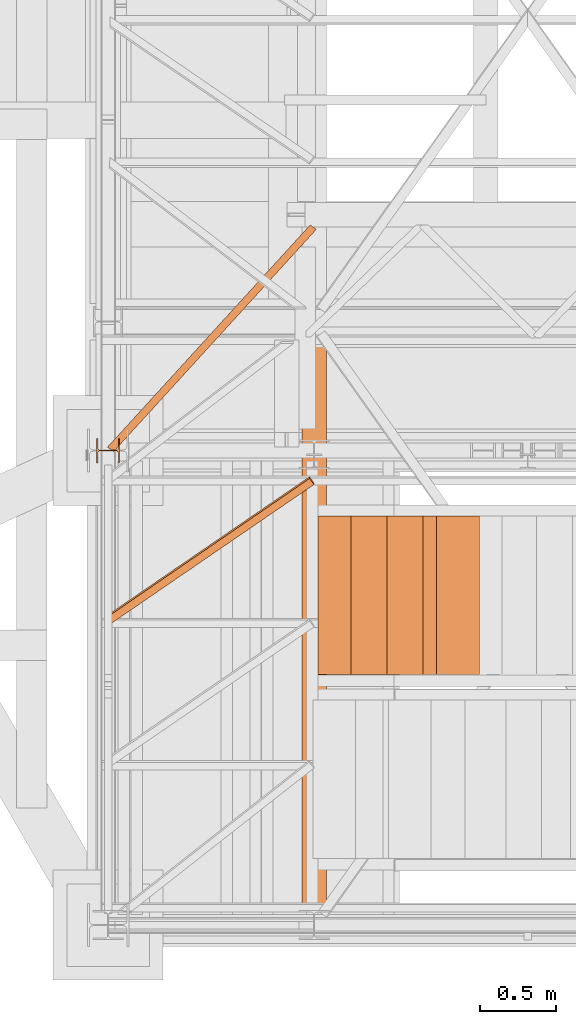
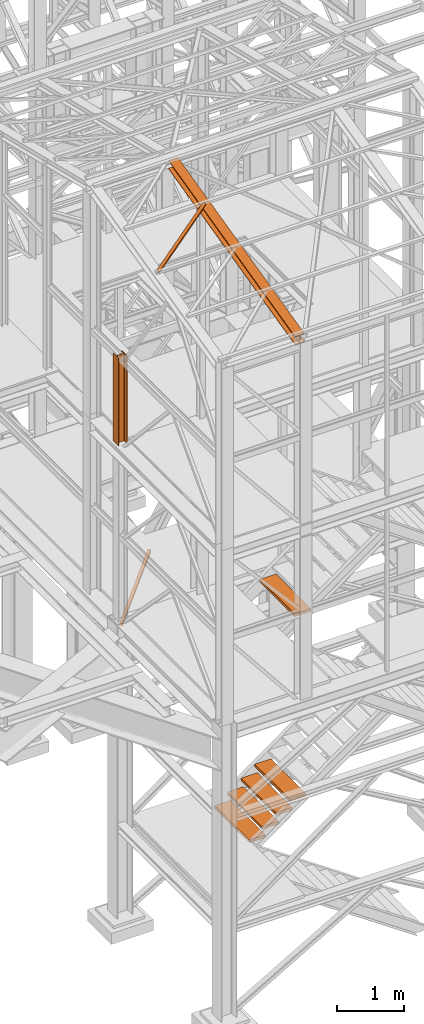
# One storey, part 14 of 208: 9 proxies.
"""IFC2X3 building model written with IfcOpenShell, lengths in millimetres."""

from ifc_helpers import new_model, entity, si_unit, converted_unit, frame, origin, origin_with_axes, place, context, subcontext, project, spatial, faceted_brep, element, save


model = new_model("IFC2X3")

# Units and contexts
model_context = context("Model", 3, precision=1e-05, world=origin())
plan_context = context("Plan", 3, precision=1e-05, world=origin())
body_context = subcontext(model_context, "Body", "Model", "MODEL_VIEW")
ifc_project = project(units=[si_unit("LENGTHUNIT", "METRE", prefix="MILLI"), converted_unit("PLANEANGLEUNIT", "DEGREE", entity("IfcPlaneAngleMeasure", 0.0174532925199433), si_unit("PLANEANGLEUNIT", "RADIAN"), dimensions=[0, 0, 0, 0, 0, 0, 0]), si_unit("AREAUNIT", "SQUARE_METRE"), si_unit("VOLUMEUNIT", "CUBIC_METRE")], contexts=[model_context, plan_context])

# Building, storey
building_placement = place(None, origin())
building = spatial("IfcBuilding", under=ifc_project, at=building_placement, CompositionType="COMPLEX")
storey_placement = place(building_placement, origin_with_axes())
storey = spatial("IfcBuildingStorey", under=building, at=storey_placement, Name="Geschoss", CompositionType="ELEMENT")

# Proxies
proxy_1_placement = place(storey_placement, frame((1193.91481775296, -22069.74199833824, 5124.989999999998), z_axis=(0.0, 0.0, 1.0), x_axis=(1.0, 0.0, 0.0)))
element("IfcBuildingElementProxy", 1, at=proxy_1_placement, inside=storey, context=body_context, shape_type="Brep", body=[
    faceted_brep([(1328.644641054631, 1486.462747256283, 50.01000000000022), (0.009999999999990905, 29.86187876008262, 50.01000000000022), (0.009999999999990905, 29.86187876008262, 0.01000000000021828), (1328.644641054631, 1486.462747256283, 0.01000000000021828), (1328.644641054631, 1486.462747256283, 0.01000000000021828), (0.009999999999990905, 29.86187876008262, 0.01000000000021828), (40.12066360076256, 0.01000000000203727, 0.01000000000021828), (1368.755304655396, 1456.610868496202, 0.01000000000021828), (1368.755304655396, 1456.610868496202, 0.01000000000021828), (40.12066360076256, 0.01000000000203727, 0.01000000000021828), (40.12066360076256, 0.01000000000203727, 50.01000000000022), (1368.755304655396, 1456.610868496202, 50.01000000000022), (1368.755304655396, 1456.610868496202, 50.01000000000022), (40.12066360076256, 0.01000000000203727, 50.01000000000022), (0.009999999999990905, 29.86187876008262, 50.01000000000022), (1328.644641054631, 1486.462747256283, 50.01000000000022), (1328.644641054631, 1486.462747256283, 50.01000000000022), (1328.644641054631, 1486.462747256283, 0.01000000000021828), (1368.755304655396, 1456.610868496202, 0.01000000000021828), (1368.755304655396, 1456.610868496202, 50.01000000000022), (1331.853494142692, 1484.074596955477, 4.010000000000218), (1331.853494142692, 1484.074596955477, 46.01000000000022), (1365.546451567335, 1458.999018797011, 46.01000000000022), (1365.546451567335, 1458.999018797011, 4.010000000000218), (0.009999999999990905, 29.86187876008262, 50.01000000000022), (40.12066360076256, 0.01000000000203727, 50.01000000000022), (40.12066360076256, 0.01000000000203727, 0.01000000000021828), (0.009999999999990905, 29.86187876008262, 0.01000000000021828), (36.91181051270155, 2.398150300810812, 46.01000000000022), (3.218853088060996, 27.47372845927748, 46.01000000000022), (3.218853088060996, 27.47372845927748, 4.010000000000218), (36.91181051270155, 2.398150300810812, 4.010000000000218), (1331.853494142692, 1484.074596955477, 46.01000000000022), (1331.853494142692, 1484.074596955477, 4.010000000000218), (3.218853088060996, 27.47372845927748, 4.010000000000218), (3.218853088060996, 27.47372845927748, 46.01000000000022), (1331.853494142692, 1484.074596955477, 4.010000000000218), (1365.546451567335, 1458.999018797011, 4.010000000000218), (36.91181051270155, 2.398150300810812, 4.010000000000218), (3.218853088060996, 27.47372845927748, 4.010000000000218), (1365.546451567335, 1458.999018797011, 4.010000000000218), (1365.546451567335, 1458.999018797011, 46.01000000000022), (36.91181051270155, 2.398150300810812, 46.01000000000022), (36.91181051270155, 2.398150300810812, 4.010000000000218), (1365.546451567335, 1458.999018797011, 46.01000000000022), (1331.853494142692, 1484.074596955477, 46.01000000000022), (3.218853088060996, 27.47372845927748, 46.01000000000022), (36.91181051270155, 2.398150300810812, 46.01000000000022)], [[[0, 1, 2, 3]], [[4, 5, 6, 7]], [[8, 9, 10, 11]], [[12, 13, 14, 15]], [[16, 17, 18, 19], [20, 21, 22, 23]], [[24, 25, 26, 27], [28, 29, 30, 31]], [[32, 33, 34, 35]], [[36, 37, 38, 39]], [[40, 41, 42, 43]], [[44, 45, 46, 47]]], orient=[[False], [False], [False], [False], [False, False], [False, False], [False], [False], [False], [False]]),
])
proxy_2_placement = place(storey_placement, frame((3263.130870336297, -23530.42800187884, 2109.990001055714), z_axis=(0.0, 0.0, 1.0), x_axis=(1.0, 0.0, 0.0)))
element("IfcBuildingElementProxy", 2, at=proxy_2_placement, inside=storey, context=body_context, shape_type="Brep", body=[
    faceted_brep([(0.01000000000021828, 0.00999999999839929, 0.01000000000021828), (280.2746556316183, 0.00999999999839929, 0.01000000000021828), (280.2746556316183, 1037.717170711916, 0.01000000000021828), (0.01000000000021828, 1037.717170711916, 0.01000000000021828), (280.2746556316183, 0.00999999999839929, 50.01000000000022), (0.01000000000021828, 0.00999999999839929, 50.01000000000022), (0.01000000000021828, 1037.717170711916, 50.01000000000022), (280.2746556316183, 1037.717170711916, 50.01000000000022), (280.2746556316183, 0.00999999999839929, 0.01000000000021828), (0.01000000000021828, 0.00999999999839929, 0.01000000000021828), (0.01000000000021828, 0.00999999999839929, 50.01000000000022), (280.2746556316183, 0.00999999999839929, 50.01000000000022), (280.2746556316183, 1037.717170711916, 0.01000000000021828), (280.2746556316183, 0.00999999999839929, 0.01000000000021828), (280.2746556316183, 0.00999999999839929, 50.01000000000022), (280.2746556316183, 1037.717170711916, 50.01000000000022), (0.01000000000021828, 1037.717170711916, 0.01000000000021828), (280.2746556316183, 1037.717170711916, 0.01000000000021828), (280.2746556316183, 1037.717170711916, 50.01000000000022), (0.01000000000021828, 1037.717170711916, 50.01000000000022), (0.01000000000021828, 0.00999999999839929, 0.01000000000021828), (0.01000000000021828, 1037.717170711916, 0.01000000000021828), (0.01000000000021828, 1037.717170711916, 50.01000000000022), (0.01000000000021828, 0.00999999999839929, 50.01000000000022)], [[[0, 1, 2, 3]], [[4, 5, 6, 7]], [[8, 9, 10, 11]], [[12, 13, 14, 15]], [[16, 17, 18, 19]], [[20, 21, 22, 23]]], orient=[[False], [False], [False], [False], [False], [False]]),
])
for number, where, z_axis, x_axis in (
    (3, (2573.108528797217, -23530.42800187884, 1599.990001055713), (0.0, 0.0, 1.0), (1.0, 0.0, 0.0)),
    (4, (2791.281494502201, -23530.42800187884, 1769.990001055714), (0.0, 0.0, 1.0), (1.0, 0.0, 0.0)),
    (5, (3027.206182419249, -23530.42800187884, 1939.990001055714), (0.0, 0.0, 1.0), (1.0, 0.0, 0.0)),
):
    element("IfcBuildingElementProxy", number, at=place(storey_placement, frame(where, z_axis=z_axis, x_axis=x_axis)), inside=storey, context=body_context, shape_type="Brep", body=[
        faceted_brep([(0.01000000000021828, 0.00999999999839929, 0.009999999999990905), (280.2746556316183, 0.00999999999839929, 0.009999999999990905), (280.2746556316183, 1037.717170711916, 0.009999999999990905), (0.01000000000021828, 1037.717170711916, 0.009999999999990905), (280.2746556316183, 0.00999999999839929, 50.00999999999999), (0.01000000000021828, 0.00999999999839929, 50.00999999999999), (0.01000000000021828, 1037.717170711916, 50.00999999999999), (280.2746556316183, 1037.717170711916, 50.00999999999999), (280.2746556316183, 0.00999999999839929, 0.009999999999990905), (0.01000000000021828, 0.00999999999839929, 0.009999999999990905), (0.01000000000021828, 0.00999999999839929, 50.00999999999999), (280.2746556316183, 0.00999999999839929, 50.00999999999999), (280.2746556316183, 1037.717170711916, 0.009999999999990905), (280.2746556316183, 0.00999999999839929, 0.009999999999990905), (280.2746556316183, 0.00999999999839929, 50.00999999999999), (280.2746556316183, 1037.717170711916, 50.00999999999999), (0.01000000000021828, 1037.717170711916, 0.009999999999990905), (280.2746556316183, 1037.717170711916, 0.009999999999990905), (280.2746556316183, 1037.717170711916, 50.00999999999999), (0.01000000000021828, 1037.717170711916, 50.00999999999999), (0.01000000000021828, 0.00999999999839929, 0.009999999999990905), (0.01000000000021828, 1037.717170711916, 0.009999999999990905), (0.01000000000021828, 1037.717170711916, 50.00999999999999), (0.01000000000021828, 0.00999999999839929, 50.00999999999999)], [[[0, 1, 2, 3]], [[4, 5, 6, 7]], [[8, 9, 10, 11]], [[12, 13, 14, 15]], [[16, 17, 18, 19]], [[20, 21, 22, 23]]], orient=[[False], [False], [False], [False], [False], [False]]),
    ])
proxy_3_placement = place(storey_placement, frame((3350.427385940221, -23530.42800187884, 5443.518109803212), z_axis=(0.0, 0.0, 1.0), x_axis=(1.0, 0.0, 0.0)))
element("IfcBuildingElementProxy", 6, at=proxy_3_placement, inside=storey, context=body_context, shape_type="Brep", body=[
    faceted_brep([(0.01000000000021828, 0.00999999999839929, 0.01000000000021828), (280.2746556316183, 0.00999999999839929, 0.01000000000021828), (280.2746556316183, 1037.717170711916, 0.01000000000021828), (0.01000000000021828, 1037.717170711916, 0.01000000000021828), (280.2746556316183, 0.00999999999839929, 50.01000000000022), (0.01000000000021828, 0.00999999999839929, 50.01000000000022), (0.01000000000021828, 1037.717170711916, 50.01000000000022), (280.2746556316183, 1037.717170711916, 50.01000000000022), (280.2746556316183, 0.00999999999839929, 0.01000000000021828), (0.01000000000021828, 0.00999999999839929, 0.01000000000021828), (0.01000000000021828, 0.00999999999839929, 50.01000000000022), (280.2746556316183, 0.00999999999839929, 50.01000000000022), (280.2746556316183, 1037.717170711916, 0.01000000000021828), (280.2746556316183, 0.00999999999839929, 0.01000000000021828), (280.2746556316183, 0.00999999999839929, 50.01000000000022), (280.2746556316183, 1037.717170711916, 50.01000000000022), (0.01000000000021828, 1037.717170711916, 0.01000000000021828), (280.2746556316183, 1037.717170711916, 0.01000000000021828), (280.2746556316183, 1037.717170711916, 50.01000000000022), (0.01000000000021828, 1037.717170711916, 50.01000000000022), (0.01000000000021828, 0.00999999999839929, 0.01000000000021828), (0.01000000000021828, 1037.717170711916, 0.01000000000021828), (0.01000000000021828, 1037.717170711916, 50.01000000000022), (0.01000000000021828, 0.00999999999839929, 50.01000000000022)], [[[0, 1, 2, 3]], [[4, 5, 6, 7]], [[8, 9, 10, 11]], [[12, 13, 14, 15]], [[16, 17, 18, 19]], [[20, 21, 22, 23]]], orient=[[False], [False], [False], [False], [False], [False]]),
])
proxy_4_placement = place(storey_placement, frame((1209.754965757053, -23201.62230478293, 12214.24717333412), z_axis=(0.0, 0.0, 1.0), x_axis=(1.0, 0.0, 0.0)))
element("IfcBuildingElementProxy", 7, at=proxy_4_placement, inside=storey, context=body_context, shape_type="Brep", body=[
    faceted_brep([(1308.5389233782, 967.7692788621098, 232.0521250666225), (1337.349720073477, 928.0575343349883, 222.4128647010039), (1337.349720073477, 916.2634686381534, 271.0019582749592), (1308.5389233782, 955.9752131652713, 280.6412186405796), (0.009999999999990905, 71.25499243027662, 14.44056628674844), (1308.5389233782, 967.7692788621098, 232.0521250666225), (1308.5389233782, 955.9752131652713, 280.6412186405796), (0.009999999999990905, 59.46092673344174, 63.02965986070558), (0.009999999999990905, 11.80406569684055, 0.01000000000021828), (1337.349720073477, 928.0575343349883, 222.4128647010039), (1308.5389233782, 967.7692788621098, 232.0521250666225), (0.009999999999990905, 71.25499243027662, 14.44056628674844), (0.009999999999990905, 0.01000000000203727, 48.59909357395554), (1337.349720073477, 916.2634686381534, 271.0019582749592), (1337.349720073477, 928.0575343349883, 222.4128647010039), (0.009999999999990905, 11.80406569684055, 0.01000000000021828), (0.009999999999990905, 59.46092673344174, 63.02965986070558), (1308.5389233782, 955.9752131652713, 280.6412186405796), (1337.349720073477, 916.2634686381534, 271.0019582749592), (0.009999999999990905, 0.01000000000203727, 48.59909357395554), (0.009999999999990905, 71.25499243027662, 14.44056628674844), (0.009999999999990905, 59.46092673344174, 63.02965986070558), (0.009999999999990905, 0.01000000000203727, 48.59909357395554), (0.009999999999990905, 11.80406569684055, 0.01000000000021828)], [[[0, 1, 2, 3]], [[4, 5, 6, 7]], [[8, 9, 10, 11]], [[12, 13, 14, 15]], [[16, 17, 18, 19]], [[20, 21, 22, 23]]], orient=[[False], [False], [False], [False], [False], [False]]),
])
proxy_5_placement = place(storey_placement, frame((2468.254966591505, -25077.57437538435, 11628.70515179705), z_axis=(0.0, 0.0, 1.0), x_axis=(1.0, 0.0, 0.0)))
element("IfcBuildingElementProxy", 8, at=proxy_5_placement, inside=storey, context=body_context, shape_type="Brep", body=[
    faceted_brep([(160.01001132489, 3780.009979404025, 1074.775244917653), (160.01001132488, 0.00999999999839929, 156.4315054631916), (0.01000000000021828, 0.00999999999839929, 156.4315054631916), (0.01000000000703949, 3780.009979404025, 1074.775244917653), (0.01000000000703949, 3780.009979404025, 1074.775244917653), (0.01000000000021828, 0.00999999999839929, 156.4315054631916), (0.01000000000021828, 0.00999999999839929, 147.1697029728093), (0.01000000000703949, 3780.009979404025, 1065.513442427271), (0.01000000000703949, 3780.009979404025, 1065.513442427271), (0.01000000000021828, 0.00999999999839929, 147.1697029728093), (62.01000457465671, 0.00999999999839929, 147.1697029728093), (62.01000457466307, 3780.009979404025, 1065.513442427271), (62.01000457466307, 3780.009979404025, 1065.513442427271), (62.01000457465671, 0.00999999999839929, 147.1697029728093), (69.77318079977886, 0.00999999999839929, 145.5707163655079), (69.77318079978886, 3780.009979404025, 1063.914455819968), (69.77318079978886, 3780.009979404025, 1063.914455819968), (69.77318079977886, 0.00999999999839929, 145.5707163655079), (75.45621545821086, 0.00999999999839929, 139.7223691397903), (75.45621545822132, 3780.009979404025, 1058.066108594254), (75.45621545822132, 3780.009979404025, 1058.066108594254), (75.45621545821086, 0.00999999999839929, 139.7223691397903), (77.0100056363608, 0.00999999999839929, 131.7333744340358), (77.0100056363708, 3780.009979404025, 1050.077113888498), (77.0100056363708, 3780.009979404025, 1050.077113888498), (77.0100056363608, 0.00999999999839929, 131.7333744340358), (77.0100056363608, 0.00999999999839929, 24.70813486281259), (77.0100056363708, 3780.009979404025, 943.0518743172743), (77.0100056363708, 3780.009979404025, 943.0518743172743), (77.0100056363608, 0.00999999999839929, 24.70813486281259), (75.45621545821086, 0.00999999999839929, 16.71913632339965), (75.45621545822087, 3780.009979404025, 935.0628757778613), (75.45621545822087, 3780.009979404025, 935.0628757778613), (75.45621545821086, 0.00999999999839929, 16.71913632339965), (69.77318079977886, 0.00999999999839929, 10.87078909768752), (69.77318079978886, 3780.009979404025, 929.2145285521474), (69.77318079978886, 3780.009979404025, 929.2145285521474), (69.77318079977886, 0.00999999999839929, 10.87078909768752), (62.01000457465307, 0.00999999999839929, 9.27180249038247), (62.01000457466307, 3780.009979404025, 927.6155419448442), (62.01000457466307, 3780.009979404025, 927.6155419448442), (62.01000457465307, 0.00999999999839929, 9.27180249038247), (0.01000000000021828, 0.00999999999839929, 9.27180249038247), (0.01000000000703949, 3780.009979404025, 927.6155419448423), (0.01000000000703949, 3780.009979404025, 927.6155419448423), (0.01000000000021828, 0.00999999999839929, 9.27180249038247), (0.01000000000021828, 0.00999999999839929, 0.01000000000021828), (0.01000000000658474, 3780.009979404025, 918.3537394544601), (0.01000000000658474, 3780.009979404025, 918.3537394544601), (0.01000000000021828, 0.00999999999839929, 0.01000000000021828), (160.0100113248827, 0.00999999999839929, 0.01000000000021828), (160.01001132489, 3780.009979404025, 918.3537394544619), (160.01001132489, 3780.009979404025, 918.3537394544619), (160.0100113248827, 0.00999999999839929, 0.01000000000021828), (160.0100113248836, 0.00999999999839929, 9.27180249038065), (160.01001132489, 3780.009979404025, 927.6155419448423), (160.01001132489, 3780.009979404025, 927.6155419448423), (160.0100113248836, 0.00999999999839929, 9.27180249038065), (98.0100067502226, 0.00999999999839929, 9.27180249038247), (98.0100067502326, 3780.009979404025, 927.6155419448423), (98.0100067502326, 3780.009979404025, 927.6155419448423), (98.0100067502226, 0.00999999999839929, 9.27180249038247), (90.24683052509681, 0.00999999999839929, 10.87078909768752), (90.24683052510682, 3780.009979404025, 929.2145285521474), (90.24683052510682, 3780.009979404025, 929.2145285521474), (90.24683052509681, 0.00999999999839929, 10.87078909768752), (84.5637958666648, 0.00999999999839929, 16.71913632339783), (84.56379586667481, 3780.009979404025, 935.0628757778613), (84.56379586667481, 3780.009979404025, 935.0628757778613), (84.5637958666648, 0.00999999999839929, 16.71913632339783), (83.01000568851487, 0.00999999999839929, 24.70813486281077), (83.01000568852487, 3780.009979404025, 943.0518743172743), (83.01000568852487, 3780.009979404025, 943.0518743172743), (83.01000568851487, 0.00999999999839929, 24.70813486281077), (83.01000568851532, 0.00999999999839929, 131.733374434034), (83.01000568852487, 3780.009979404025, 1050.077113888496), (83.01000568852487, 3780.009979404025, 1050.077113888496), (83.01000568851532, 0.00999999999839929, 131.733374434034), (84.5637958666648, 0.00999999999839929, 139.7223691397903), (84.56379586667526, 3780.009979404025, 1058.066108594254), (84.56379586667526, 3780.009979404025, 1058.066108594254), (84.5637958666648, 0.00999999999839929, 139.7223691397903), (90.24683052509727, 0.00999999999839929, 145.5707163655079), (90.24683052510727, 3780.009979404025, 1063.914455819968), (90.24683052510727, 3780.009979404025, 1063.914455819968), (90.24683052509727, 0.00999999999839929, 145.5707163655079), (98.0100067502226, 0.00999999999839929, 147.1697029728093), (98.0100067502326, 3780.009979404025, 1065.513442427271), (98.0100067502326, 3780.009979404025, 1065.513442427271), (98.0100067502226, 0.00999999999839929, 147.1697029728093), (160.0100113248832, 0.00999999999839929, 147.1697029728093), (160.01001132489, 3780.009979404025, 1065.513442427271), (160.01001132489, 3780.009979404025, 1065.513442427271), (160.0100113248832, 0.00999999999839929, 147.1697029728093), (160.01001132488, 0.00999999999839929, 156.4315054631916), (160.01001132489, 3780.009979404025, 1074.775244917653), (0.01000000000703949, 3780.009979404025, 1074.775244917653), (0.01000000000703949, 3780.009979404025, 1065.513442427271), (62.01000457466307, 3780.009979404025, 1065.513442427271), (69.77318079978886, 3780.009979404025, 1063.914455819968), (75.45621545822132, 3780.009979404025, 1058.066108594254), (77.0100056363708, 3780.009979404025, 1050.077113888498), (77.0100056363708, 3780.009979404025, 943.0518743172743), (75.45621545822087, 3780.009979404025, 935.0628757778613), (69.77318079978886, 3780.009979404025, 929.2145285521474), (62.01000457466307, 3780.009979404025, 927.6155419448442), (0.01000000000703949, 3780.009979404025, 927.6155419448423), (0.01000000000658474, 3780.009979404025, 918.3537394544601), (160.01001132489, 3780.009979404025, 918.3537394544619), (160.01001132489, 3780.009979404025, 927.6155419448423), (98.0100067502326, 3780.009979404025, 927.6155419448423), (90.24683052510682, 3780.009979404025, 929.2145285521474), (84.56379586667481, 3780.009979404025, 935.0628757778613), (83.01000568852487, 3780.009979404025, 943.0518743172743), (83.01000568852487, 3780.009979404025, 1050.077113888496), (84.56379586667526, 3780.009979404025, 1058.066108594254), (90.24683052510727, 3780.009979404025, 1063.914455819968), (98.0100067502326, 3780.009979404025, 1065.513442427271), (160.01001132489, 3780.009979404025, 1065.513442427271), (160.01001132489, 3780.009979404025, 1074.775244917653), (160.01001132488, 0.00999999999839929, 156.4315054631916), (160.0100113248832, 0.00999999999839929, 147.1697029728093), (98.0100067502226, 0.00999999999839929, 147.1697029728093), (90.24683052509727, 0.00999999999839929, 145.5707163655079), (84.5637958666648, 0.00999999999839929, 139.7223691397903), (83.01000568851532, 0.00999999999839929, 131.733374434034), (83.01000568851487, 0.00999999999839929, 24.70813486281077), (84.5637958666648, 0.00999999999839929, 16.71913632339783), (90.24683052509681, 0.00999999999839929, 10.87078909768752), (98.0100067502226, 0.00999999999839929, 9.27180249038247), (160.0100113248836, 0.00999999999839929, 9.27180249038065), (160.0100113248827, 0.00999999999839929, 0.01000000000021828), (0.01000000000021828, 0.00999999999839929, 0.01000000000021828), (0.01000000000021828, 0.00999999999839929, 9.27180249038247), (62.01000457465307, 0.00999999999839929, 9.27180249038247), (69.77318079977886, 0.00999999999839929, 10.87078909768752), (75.45621545821086, 0.00999999999839929, 16.71913632339965), (77.0100056363608, 0.00999999999839929, 24.70813486281259), (77.0100056363608, 0.00999999999839929, 131.7333744340358), (75.45621545821086, 0.00999999999839929, 139.7223691397903), (69.77318079977886, 0.00999999999839929, 145.5707163655079), (62.01000457465671, 0.00999999999839929, 147.1697029728093), (0.01000000000021828, 0.00999999999839929, 147.1697029728093), (0.01000000000021828, 0.00999999999839929, 156.4315054631916)], [[[0, 1, 2, 3]], [[4, 5, 6, 7]], [[8, 9, 10, 11]], [[12, 13, 14, 15]], [[16, 17, 18, 19]], [[20, 21, 22, 23]], [[24, 25, 26, 27]], [[28, 29, 30, 31]], [[32, 33, 34, 35]], [[36, 37, 38, 39]], [[40, 41, 42, 43]], [[44, 45, 46, 47]], [[48, 49, 50, 51]], [[52, 53, 54, 55]], [[56, 57, 58, 59]], [[60, 61, 62, 63]], [[64, 65, 66, 67]], [[68, 69, 70, 71]], [[72, 73, 74, 75]], [[76, 77, 78, 79]], [[80, 81, 82, 83]], [[84, 85, 86, 87]], [[88, 89, 90, 91]], [[92, 93, 94, 95]], [[96, 97, 98, 99, 100, 101, 102, 103, 104, 105, 106, 107, 108, 109, 110, 111, 112, 113, 114, 115, 116, 117, 118, 119]], [[120, 121, 122, 123, 124, 125, 126, 127, 128, 129, 130, 131, 132, 133, 134, 135, 136, 137, 138, 139, 140, 141, 142, 143]]], orient=[[False], [False], [False], [False], [False], [False], [False], [False], [False], [False], [False], [False], [False], [False], [False], [False], [False], [False], [False], [False], [False], [False], [False], [False], [False], [False]]),
])
proxy_6_placement = place(storey_placement, frame((1122.164811912571, -22142.57439598033, 8484.990002086159), z_axis=(0.0, 0.0, 1.0), x_axis=(1.0, 0.0, 0.0)))
element("IfcBuildingElementProxy", 9, at=proxy_6_placement, inside=storey, context=body_context, shape_type="Brep", body=[
    faceted_brep([(152.0100100135803, 0.01000000000203727, 0.00999999999839929), (152.0100100135803, 160.0100113248845, 0.00999999999839929), (143.0100066757202, 160.0100113248845, 0.00999999999839929), (143.0100066757202, 98.01000675022806, 0.00999999999839929), (141.4562178945541, 90.24683052510227, 0.00999999999839929), (135.7731832361221, 84.56379586667026, 0.00999999999839929), (128.0100098049641, 83.01000568852032, 0.00999999999839929), (24.01000393390655, 83.01000568852032, 0.00999999999839929), (16.24682677745818, 84.56379586667026, 0.00999999999839929), (10.56379211902618, 90.24683052510227, 0.00999999999839929), (9.010003337860098, 98.01000675022806, 0.00999999999839929), (9.010003337860098, 160.0100113248845, 0.00999999999839929), (0.009999999999990905, 160.0100113248845, 0.00999999999839929), (0.009999999999990905, 0.01000000000203727, 0.00999999999839929), (9.010003337860098, 0.01000000000203727, 0.00999999999839929), (9.010003337860098, 62.01000457465852, 0.00999999999839929), (10.56379211902618, 69.77318079978431, 0.00999999999839929), (16.24682677745818, 75.45621545821632, 0.00999999999839929), (24.01000393390655, 77.01000563636626, 0.00999999999839929), (128.0100098049641, 77.01000563636626, 0.00999999999839929), (135.7731832361221, 75.45621545821632, 0.00999999999839929), (141.4562178945541, 69.77318079978431, 0.00999999999839929), (143.0100066757202, 62.01000457465852, 0.00999999999839929), (143.0100066757202, 0.01000000000203727, 0.00999999999839929), (152.0100100135803, 160.0100113248845, 0.00999999999839929), (152.0100100135803, 0.01000000000203727, 0.00999999999839929), (152.0100100135803, 0.01000000000203727, 1595.009998658896), (152.0100100135812, 160.0100113248882, 1595.009998658894), (143.0100066757202, 160.0100113248845, 0.00999999999839929), (152.0100100135803, 160.0100113248845, 0.00999999999839929), (152.0100100135812, 160.0100113248882, 1595.009998658894), (143.0100066757202, 160.0100113248845, 1595.009998658894), (143.0100066757202, 98.01000675022806, 0.00999999999839929), (143.0100066757202, 160.0100113248845, 0.00999999999839929), (143.0100066757202, 160.0100113248845, 1595.009998658894), (143.0100066757202, 98.01000675022806, 1595.009998658894), (141.4562178945541, 90.24683052510227, 0.00999999999839929), (143.0100066757202, 98.01000675022806, 0.00999999999839929), (143.0100066757202, 98.01000675022806, 1595.009998658894), (141.4562178945541, 90.24683052510227, 1595.009998658894), (135.7731832361221, 84.56379586667026, 0.00999999999839929), (141.4562178945541, 90.24683052510227, 0.00999999999839929), (141.4562178945541, 90.24683052510227, 1595.009998658894), (135.7731832361221, 84.56379586667026, 1595.009998658892), (128.0100098049641, 83.01000568852032, 0.00999999999839929), (135.7731832361221, 84.56379586667026, 0.00999999999839929), (135.7731832361221, 84.56379586667026, 1595.009998658892), (128.0100098049641, 83.01000568852032, 1595.009998658894), (24.01000393390655, 83.01000568852032, 0.00999999999839929), (128.0100098049641, 83.01000568852032, 0.00999999999839929), (128.0100098049641, 83.01000568852032, 1595.009998658894), (24.01000393390655, 83.01000568852032, 1595.009998658894), (16.24682677745818, 84.56379586667026, 0.00999999999839929), (24.01000393390655, 83.01000568852032, 0.00999999999839929), (24.01000393390655, 83.01000568852032, 1595.009998658894), (16.24682677745818, 84.56379586667026, 1595.009998658894), (10.56379211902618, 90.24683052510227, 0.00999999999839929), (16.24682677745818, 84.56379586667026, 0.00999999999839929), (16.24682677745818, 84.56379586667026, 1595.009998658894), (10.56379211902618, 90.24683052510227, 1595.009998658894), (9.010003337860098, 98.01000675022806, 0.00999999999839929), (10.56379211902618, 90.24683052510227, 0.00999999999839929), (10.56379211902618, 90.24683052510227, 1595.009998658894), (9.010003337860098, 98.01000675022806, 1595.009998658894), (9.010003337860098, 160.0100113248845, 0.00999999999839929), (9.010003337860098, 98.01000675022806, 0.00999999999839929), (9.010003337860098, 98.01000675022806, 1595.009998658894), (9.010003337860098, 160.0100113248882, 1595.009998658894), (0.009999999999990905, 160.0100113248845, 0.00999999999839929), (9.010003337860098, 160.0100113248845, 0.00999999999839929), (9.010003337860098, 160.0100113248882, 1595.009998658894), (0.009999999999990905, 160.0100113248845, 1595.009998658894), (0.009999999999990905, 0.01000000000203727, 0.00999999999839929), (0.009999999999990905, 160.0100113248845, 0.00999999999839929), (0.009999999999990905, 160.0100113248845, 1595.009998658894), (0.009999999999990905, 0.01000000000203727, 1595.009998658894), (9.010003337860098, 0.01000000000203727, 0.00999999999839929), (0.009999999999990905, 0.01000000000203727, 0.00999999999839929), (0.009999999999990905, 0.01000000000203727, 1595.009998658894), (9.010003337860098, 0.01000000000203727, 1595.009998658894), (9.010003337860098, 62.01000457465852, 0.00999999999839929), (9.010003337860098, 0.01000000000203727, 0.00999999999839929), (9.010003337860098, 0.01000000000203727, 1595.009998658894), (9.010003337861008, 62.01000457465852, 1595.009998658894), (10.56379211902618, 69.77318079978431, 0.00999999999839929), (9.010003337860098, 62.01000457465852, 0.00999999999839929), (9.010003337861008, 62.01000457465852, 1595.009998658894), (10.56379211902618, 69.77318079978431, 1595.009998658894), (16.24682677745818, 75.45621545821632, 0.00999999999839929), (10.56379211902618, 69.77318079978431, 0.00999999999839929), (10.56379211902618, 69.77318079978431, 1595.009998658894), (16.24682677745818, 75.45621545821632, 1595.009998658894), (24.01000393390655, 77.01000563636626, 0.00999999999839929), (16.24682677745818, 75.45621545821632, 0.00999999999839929), (16.24682677745818, 75.45621545821632, 1595.009998658894), (24.01000393390655, 77.0100056363699, 1595.009998658894), (128.0100098049641, 77.01000563636626, 0.00999999999839929), (24.01000393390655, 77.01000563636626, 0.00999999999839929), (24.01000393390655, 77.0100056363699, 1595.009998658894), (128.010009804965, 77.01000563636626, 1595.009998658894), (135.7731832361221, 75.45621545821632, 0.00999999999839929), (128.0100098049641, 77.01000563636626, 0.00999999999839929), (128.010009804965, 77.01000563636626, 1595.009998658894), (135.7731832361221, 75.45621545821632, 1595.009998658894), (141.4562178945541, 69.77318079978431, 0.00999999999839929), (135.7731832361221, 75.45621545821632, 0.00999999999839929), (135.7731832361221, 75.45621545821632, 1595.009998658894), (141.4562178945541, 69.77318079978431, 1595.009998658894), (143.0100066757202, 62.01000457465852, 0.00999999999839929), (141.4562178945541, 69.77318079978431, 0.00999999999839929), (141.4562178945541, 69.77318079978431, 1595.009998658894), (143.0100066757202, 62.01000457465852, 1595.009998658894), (143.0100066757202, 0.01000000000203727, 0.00999999999839929), (143.0100066757202, 62.01000457465852, 0.00999999999839929), (143.0100066757202, 62.01000457465852, 1595.009998658894), (143.0100066757202, 0.01000000000203727, 1595.009998658896), (152.0100100135803, 0.01000000000203727, 0.00999999999839929), (143.0100066757202, 0.01000000000203727, 0.00999999999839929), (143.0100066757202, 0.01000000000203727, 1595.009998658896), (152.0100100135803, 0.01000000000203727, 1595.009998658896), (0.009999999999990905, 0.01000000000203727, 1595.009998658894), (0.009999999999990905, 160.0100113248845, 1595.009998658894), (9.010003337860098, 160.0100113248882, 1595.009998658894), (9.010003337860098, 98.01000675022806, 1595.009998658894), (10.56379211902618, 90.24683052510227, 1595.009998658894), (16.24682677745818, 84.56379586667026, 1595.009998658894), (24.01000393390655, 83.01000568852032, 1595.009998658894), (128.0100098049641, 83.01000568852032, 1595.009998658894), (135.7731832361221, 84.56379586667026, 1595.009998658892), (141.4562178945541, 90.24683052510227, 1595.009998658894), (143.0100066757202, 98.01000675022806, 1595.009998658894), (143.0100066757202, 160.0100113248845, 1595.009998658894), (152.0100100135812, 160.0100113248882, 1595.009998658894), (152.0100100135803, 0.01000000000203727, 1595.009998658896), (143.0100066757202, 0.01000000000203727, 1595.009998658896), (143.0100066757202, 62.01000457465852, 1595.009998658894), (141.4562178945541, 69.77318079978431, 1595.009998658894), (135.7731832361221, 75.45621545821632, 1595.009998658894), (128.010009804965, 77.01000563636626, 1595.009998658894), (24.01000393390655, 77.0100056363699, 1595.009998658894), (16.24682677745818, 75.45621545821632, 1595.009998658894), (10.56379211902618, 69.77318079978431, 1595.009998658894), (9.010003337861008, 62.01000457465852, 1595.009998658894), (9.010003337860098, 0.01000000000203727, 1595.009998658894)], [[[0, 1, 2, 3, 4, 5, 6, 7, 8, 9, 10, 11, 12, 13, 14, 15, 16, 17, 18, 19, 20, 21, 22, 23]], [[24, 25, 26, 27]], [[28, 29, 30, 31]], [[32, 33, 34, 35]], [[36, 37, 38, 39]], [[40, 41, 42, 43]], [[44, 45, 46, 47]], [[48, 49, 50, 51]], [[52, 53, 54, 55]], [[56, 57, 58, 59]], [[60, 61, 62, 63]], [[64, 65, 66, 67]], [[68, 69, 70, 71]], [[72, 73, 74, 75]], [[76, 77, 78, 79]], [[80, 81, 82, 83]], [[84, 85, 86, 87]], [[88, 89, 90, 91]], [[92, 93, 94, 95]], [[96, 97, 98, 99]], [[100, 101, 102, 103]], [[104, 105, 106, 107]], [[108, 109, 110, 111]], [[112, 113, 114, 115]], [[116, 117, 118, 119]], [[120, 121, 122, 123, 124, 125, 126, 127, 128, 129, 130, 131, 132, 133, 134, 135, 136, 137, 138, 139, 140, 141, 142, 143]]], orient=[[False], [False], [False], [False], [False], [False], [False], [False], [False], [False], [False], [False], [False], [False], [False], [False], [False], [False], [False], [False], [False], [False], [False], [False], [False], [False]]),
])

save(model, "model.ifc")
